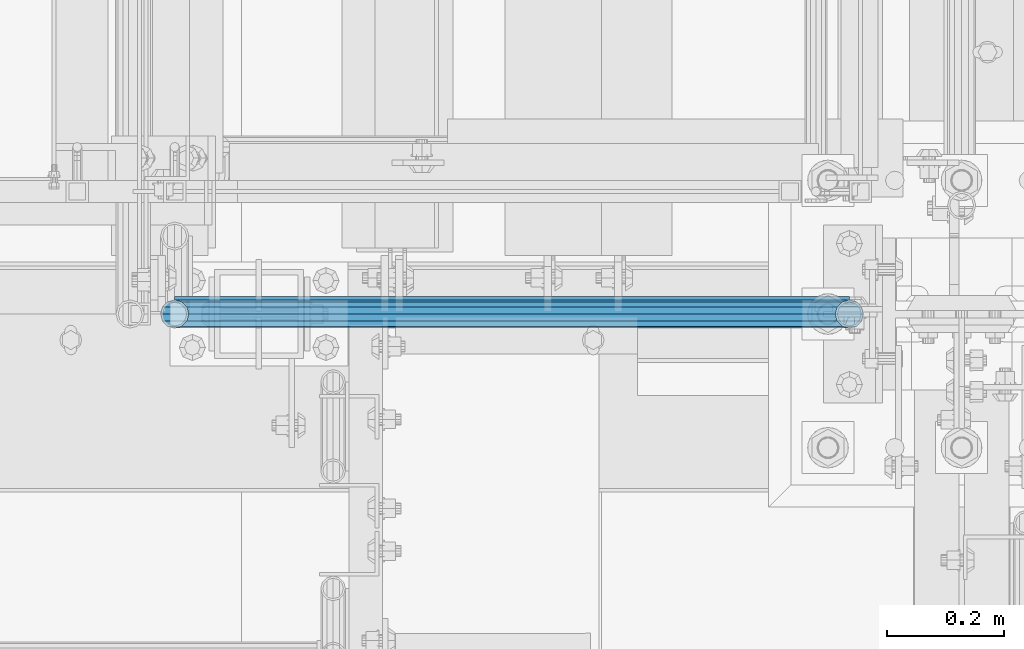
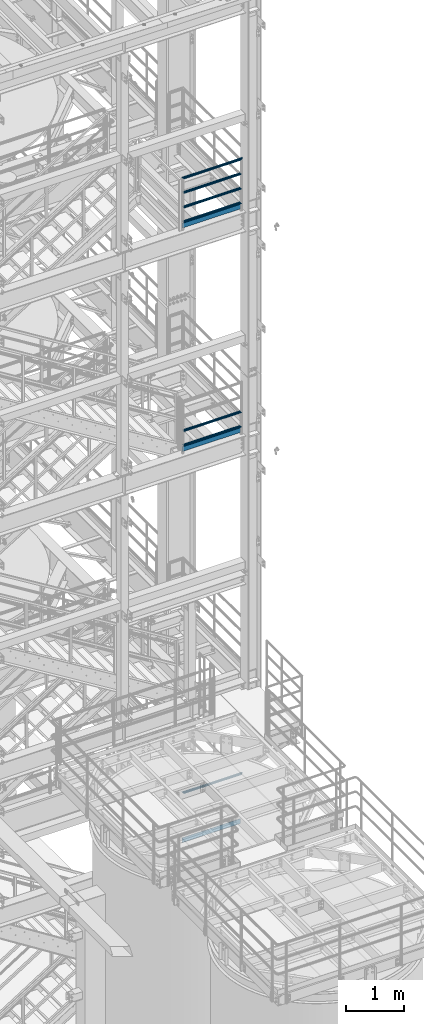
# One storey, part 949 of 1876: 10 beams, 3 elements without a shape of their own.
"""IFC2X3 building model written with IfcOpenShell, lengths in millimetres."""

from ifc_helpers import new_model, si_unit, frame, origin_with_axes, place, context, subcontext, project, spatial, faceted_brep, material, type_object, element, aggregate, save


model = new_model("IFC2X3")

# Units and contexts
model_context = context("Model", 3, precision=1e-05, world=origin_with_axes())
body_context = subcontext(model_context, "Body", "Model", "MODEL_VIEW")
ifc_project = project(units=[si_unit("LENGTHUNIT", "METRE", prefix="MILLI"), si_unit("AREAUNIT", "SQUARE_METRE"), si_unit("VOLUMEUNIT", "CUBIC_METRE"), si_unit("MASSUNIT", "GRAM", prefix="KILO"), si_unit("TIMEUNIT", "SECOND"), si_unit("PLANEANGLEUNIT", "RADIAN"), si_unit("SOLIDANGLEUNIT", "STERADIAN"), si_unit("THERMODYNAMICTEMPERATUREUNIT", "DEGREE_CELSIUS"), si_unit("LUMINOUSINTENSITYUNIT", "LUMEN")], contexts=[model_context])

# Site, building, storey
site_placement = place(None, origin_with_axes())
site = spatial("IfcSite", under=ifc_project, at=site_placement, CompositionType="ELEMENT")
building_placement = place(site_placement, origin_with_axes())
building = spatial("IfcBuilding", under=site, at=building_placement, Name="Undefined", CompositionType="ELEMENT")
storey_placement = place(building_placement, origin_with_axes())
storey = spatial("IfcBuildingStorey", under=building, at=storey_placement, Name="Undefined", CompositionType="ELEMENT", Elevation=0.0)

# Assembly, beam
assembly_1_placement = place(storey_placement, origin_with_axes())
assembly_1 = element("IfcElementAssembly", 1, at=assembly_1_placement, inside=storey, Name="RAIL", AssemblyPlace="NOTDEFINED", PredefinedType="RIGID_FRAME")
ifc_material_1 = material()
beam_type_1 = type_object("IfcBeamType", Name="PIPE1-1/2SCH40", PredefinedType="NOTDEFINED")
beam_1_placement = place(assembly_1_placement, frame((6249.67016410903, -7112.0, 6207.12499999999), z_axis=(0.0, 0.0, -1.0), x_axis=(1.0, 0.0, 0.0)))
beam_1 = element("IfcBeam", 2, at=beam_1_placement, type_object=beam_type_1, material=ifc_material_1, Name="RAIL", ObjectType="PIPE1-1/2SCH40", context=body_context, shape_type="Brep", body=[
    faceted_brep([(24.1300000000001, -20.4469999999999, 0.0), (34.3535000000002, -17.7076214311803, 10.2235000000001), (1168.01883589097, -17.7076214311801, 10.2235000000001), (1178.24233589097, -20.4470000000001, 0.0), (41.8376214311802, -10.2235000000001, 17.7076214311819), (1160.53471445979, -10.2235000000001, 17.7076214311801), (44.5770000000002, 0.0, 20.4470000000001), (1157.79533589097, 0.0, 20.4470000000001), (41.8376214311802, 10.2235000000001, 17.7076214311819), (1160.53471445979, 10.2235000000001, 17.7076214311801), (34.3535000000002, 17.7076214311803, 10.2235000000001), (1168.01883589097, 17.7076214311801, 10.2235000000001), (24.1300000000001, 20.4469999999999, 0.0), (1178.24233589097, 20.4470000000001, 0.0), (13.9065000000001, 17.7076214311803, -10.2235000000001), (1188.46583589097, 17.7076214311801, -10.2235000000001), (6.42237856882002, 10.2235000000001, -17.7076214311819), (1195.94995732215, 10.2235000000001, -17.7076214311801), (3.68299999999999, 0.0, -20.4470000000001), (1198.68933589097, 0.0, -20.4470000000001), (6.42237856882002, -10.2235000000001, -17.7076214311819), (1195.94995732215, -10.2235000000001, -17.7076214311801), (13.9065000000001, -17.7076214311803, -10.2235000000001), (1188.46583589097, -17.7076214311801, -10.2235000000001), (24.1299999999854, -24.1299999999992, 0.0), (12.0650000000064, -20.8971929933177, -12.0649999999987), (1190.30733589097, -20.8971929933186, -12.0649999999996), (1178.24233589097, -24.1300000000001, 0.0), (3.23280700668147, -12.0650000000001, -20.8971929933177), (1199.13952888429, -12.0649999999996, -20.8971929933186), (-1.45519152283669e-11, 0.0, -24.130000000001), (1202.37233589097, 0.0, -24.1300000000001), (3.23280700668147, 12.0650000000001, -20.8971929933177), (1199.13952888429, 12.0649999999996, -20.8971929933186), (12.0650000000064, 20.8971929933177, -12.0649999999987), (1190.30733589097, 20.8971929933186, -12.0649999999996), (24.1300000000047, 24.1299999999992, 0.0), (1178.24233589097, 24.1300000000001, 0.0), (36.1949999999997, 20.8971929933184, 12.0649999999987), (1166.17733589097, 20.8971929933186, 12.0649999999996), (45.0271929933187, 12.0650000000001, 20.8971929933177), (1157.34514289765, 12.0649999999996, 20.8971929933186), (48.2600000000002, 0.0, 24.130000000001), (1154.11233589097, 0.0, 24.1300000000001), (45.0271929933187, -12.0650000000001, 20.8971929933177), (1157.34514289765, -12.0649999999996, 20.8971929933186), (36.1949999999997, -20.8971929933184, 12.0649999999987), (1166.17733589097, -20.8971929933186, 12.0649999999996)], [[[0, 1, 2, 3]], [[1, 4, 5, 2]], [[4, 6, 7, 5]], [[6, 8, 9, 7]], [[8, 10, 11, 9]], [[10, 12, 13, 11]], [[12, 14, 15, 13]], [[14, 16, 17, 15]], [[16, 18, 19, 17]], [[18, 20, 21, 19]], [[20, 22, 23, 21]], [[22, 0, 3, 23]], [[24, 25, 26, 27]], [[25, 28, 29, 26]], [[28, 30, 31, 29]], [[30, 32, 33, 31]], [[32, 34, 35, 33]], [[34, 36, 37, 35]], [[36, 38, 39, 37]], [[38, 40, 41, 39]], [[40, 42, 43, 41]], [[42, 44, 45, 43]], [[44, 46, 47, 45]], [[46, 24, 27, 47]], [[29, 31, 33, 35, 37, 39, 41, 43, 45, 47, 27, 26], [5, 7, 9, 11, 13, 15, 17, 19, 21, 23, 3, 2]], [[46, 44, 42, 40, 38, 36, 34, 32, 30, 28, 25, 24], [22, 20, 18, 16, 14, 12, 10, 8, 6, 4, 1, 0]]]),
])

# Assembly, beams
assembly_2_placement = place(storey_placement, origin_with_axes())
assembly_2 = element("IfcElementAssembly", 3, at=assembly_2_placement, inside=storey, Name="RAIL", AssemblyPlace="NOTDEFINED", PredefinedType="RIGID_FRAME")
beam_2_placement = place(assembly_2_placement, frame((7427.9125, -7112.0, 18145.125), z_axis=(0.0, 0.0, 1.0), x_axis=(-1.0, 0.0, 0.0)))
beam_2 = element("IfcBeam", 4, at=beam_2_placement, type_object=beam_type_1, material=ifc_material_1, Name="RAIL", ObjectType="PIPE1-1/2SCH40", context=body_context, shape_type="Brep", body=[
    faceted_brep([(1133.21514289765, -12.0649999999996, 20.8971929933186), (1133.21514289765, -12.0649999999996, 15.8661214311805), (1132.72171445979, -10.2235000000001, 17.7076214311801), (1129.98233589097, 0.0, 20.4470000000001), (1129.98233589097, 0.0, 24.1300000000001), (1132.72171445979, 10.2235000000001, 17.7076214311801), (1133.21514289765, 12.0649999999996, 15.8661214311805), (1133.21514289765, 12.0649999999996, 20.8971929933186), (1154.11233589097, 24.1300000000001, 0.0), (1142.04733589097, 20.8971929933186, 12.0649999999996), (1142.04733589097, 20.8971929933186, -12.0649999999996), (1138.85776432883, 17.7076214311801, 10.2235000000001), (1141.59714289765, 20.4470000000001, 0.0), (1138.85776432883, 17.7076214311801, -10.2235000000001), (1133.21514289765, 12.0649999999996, -15.8661214311805), (1133.21514289765, 12.0649999999996, -20.8971929933186), (1132.72171445979, 10.2235000000001, -17.7076214311801), (1129.98233589097, 0.0, -20.4470000000001), (1129.98233589097, 0.0, -24.1300000000001), (1133.21514289765, -12.0649999999996, -15.8661214311805), (1133.21514289765, -12.0649999999996, -20.8971929933186), (1132.72171445979, -10.2235000000001, -17.7076214311801), (1154.11233589097, -24.1300000000001, 0.0), (1142.04733589097, -20.8971929933186, -12.0649999999996), (1142.04733589097, -20.8971929933186, 12.0649999999996), (1138.85776432883, -17.7076214311801, -10.2235000000001), (1141.59714289765, -20.4470000000001, 0.0), (1138.85776432883, -17.7076214311801, 10.2235000000001), (12.0650000000064, -20.8971929933177, -12.0649999999987), (20.8971929933249, -12.0650000000005, -20.8971929933177), (0.0, 24.1299999999992, 0.0), (12.0650000000064, 20.8971929933177, -12.0649999999987), (12.0650000000064, 20.8971929933177, 12.0649999999987), (20.8971929933249, 12.0650000000005, 20.8971929933177), (24.1300000000064, 0.0, 24.130000000001), (20.8971929933249, 12.0650000000005, -20.8971929933177), (24.1300000000063, 0.0, -24.130000000001), (24.1300000000063, 0.0, -20.4470000000001), (20.8971929933249, -12.0650000000005, -15.8661214311796), (21.3906214311868, -10.2235000000001, -17.7076214311819), (21.3906214311868, 10.2235000000001, -17.7076214311819), (20.8971929933249, 12.0650000000005, -15.8661214311796), (15.2545715621445, 17.7076214311801, -10.2235000000001), (12.5151929933249, 20.4470000000001, 0.0), (15.2545715621445, 17.7076214311801, 10.2235000000001), (20.8971929933249, 12.0650000000005, 15.8661214311796), (21.3906214311868, 10.2235000000001, 17.7076214311819), (24.1300000000064, 0.0, 20.4470000000001), (21.3906214311868, -10.2235000000001, 17.7076214311819), (20.8971929933249, -12.0650000000005, 15.8661214311796), (20.8971929933249, -12.0650000000005, 20.8971929933177), (12.0650000000064, -20.8971929933177, 12.0649999999987), (0.0, -24.1299999999992, 0.0), (15.2545715621445, -17.7076214311801, 10.2235000000001), (12.5151929933249, -20.4470000000001, 0.0), (15.2545715621445, -17.7076214311801, -10.2235000000001)], [[[0, 1, 2, 3, 4]], [[4, 3, 5, 6, 7]], [[8, 9, 10]], [[7, 6, 11, 12, 13, 14, 15, 10, 9]], [[16, 17, 18, 15, 14]], [[19, 20, 18, 17, 21]], [[22, 23, 24]], [[24, 23, 20, 19, 25, 26, 27, 1, 0]], [[28, 29, 20, 23]], [[30, 31, 32]], [[33, 34, 4, 7]], [[32, 33, 7, 9]], [[30, 32, 9, 8]], [[31, 30, 8, 10]], [[35, 31, 10, 15]], [[36, 35, 15, 18]], [[29, 36, 18, 20]], [[37, 36, 29, 38, 39]], [[40, 41, 35, 36, 37]], [[32, 31, 35, 41, 42, 43, 44, 45, 33]], [[33, 45, 46, 47, 34]], [[34, 47, 48, 49, 50]], [[34, 50, 0, 4]], [[50, 51, 24, 0]], [[51, 52, 22, 24]], [[52, 28, 23, 22]], [[51, 28, 52]], [[50, 49, 53, 54, 55, 38, 29, 28, 51]], [[55, 54, 26, 25]], [[21, 39, 38, 55, 25, 19]], [[37, 39, 21, 17]], [[40, 37, 17, 16]], [[42, 41, 40, 16, 14, 13]], [[43, 42, 13, 12]], [[44, 43, 12, 11]], [[5, 46, 45, 44, 11, 6]], [[47, 46, 5, 3]], [[48, 47, 3, 2]], [[53, 49, 48, 2, 1, 27]], [[54, 53, 27, 26]]]),
])
beam_3_placement = place(assembly_2_placement, frame((6273.80016410903, -7112.0, 18449.925), z_axis=(0.0, 0.0, -1.0), x_axis=(1.0, 0.0, 0.0)))
beam_3 = element("IfcBeam", 5, at=beam_3_placement, type_object=beam_type_1, material=ifc_material_1, Name="RAIL", ObjectType="PIPE1-1/2SCH40", context=body_context, shape_type="Brep", body=[
    faceted_brep([(0.0, 24.1299999999992, 0.0), (12.0650000000064, 20.8971929933177, -12.0649999999987), (12.0650000000064, 20.8971929933177, 12.0649999999987), (12.0650000000064, -20.8971929933177, 12.0649999999987), (12.0650000000064, -20.8971929933177, -12.0649999999987), (0.0, -24.1299999999992, 0.0), (20.8971929933249, -12.0650000000005, 20.8971929933177), (20.8971929933249, -12.0650000000005, 15.8661214311796), (15.2545715621445, -17.7076214311801, 10.2235000000001), (12.5151929933249, -20.4470000000001, 0.0), (15.2545715621445, -17.7076214311801, -10.2235000000001), (20.8971929933249, -12.0650000000005, -15.8661214311796), (20.8971929933249, -12.0650000000005, -20.8971929933177), (24.1300000000063, 0.0, -20.4470000000001), (24.1300000000063, 0.0, -24.130000000001), (21.3906214311868, -10.2235000000001, -17.7076214311819), (21.3906214311868, 10.2235000000001, -17.7076214311819), (20.8971929933249, 12.0650000000005, -15.8661214311796), (20.8971929933249, 12.0650000000005, -20.8971929933177), (15.2545715621445, 17.7076214311801, -10.2235000000001), (12.5151929933249, 20.4470000000001, 0.0), (15.2545715621445, 17.7076214311801, 10.2235000000001), (20.8971929933249, 12.0650000000005, 15.8661214311796), (20.8971929933249, 12.0650000000005, 20.8971929933177), (21.3906214311868, 10.2235000000001, 17.7076214311819), (24.1300000000064, 0.0, 20.4470000000001), (24.1300000000064, 0.0, 24.130000000001), (21.3906214311868, -10.2235000000001, 17.7076214311819), (1154.11233589097, 24.1300000000001, 0.0), (1142.04733589097, 20.8971929933186, -12.0649999999996), (1133.21514289765, 12.0649999999996, -20.8971929933186), (1154.11233589097, -24.1300000000001, 0.0), (1142.04733589097, -20.8971929933186, -12.0649999999996), (1142.04733589097, -20.8971929933186, 12.0649999999996), (1133.21514289765, -12.0649999999996, 20.8971929933186), (1133.21514289765, -12.0649999999996, -20.8971929933186), (1129.98233589097, 0.0, -24.1300000000001), (1132.72171445979, 10.2235000000001, -17.7076214311801), (1129.98233589097, 0.0, -20.4470000000001), (1133.21514289765, 12.0649999999996, -15.8661214311805), (1133.21514289765, -12.0649999999996, -15.8661214311805), (1132.72171445979, -10.2235000000001, -17.7076214311801), (1138.85776432883, -17.7076214311801, -10.2235000000001), (1141.59714289765, -20.4470000000001, 0.0), (1138.85776432883, -17.7076214311801, 10.2235000000001), (1133.21514289765, -12.0649999999996, 15.8661214311805), (1132.72171445979, -10.2235000000001, 17.7076214311801), (1129.98233589097, 0.0, 20.4470000000001), (1129.98233589097, 0.0, 24.1300000000001), (1133.21514289765, 12.0649999999996, 20.8971929933186), (1142.04733589097, 20.8971929933186, 12.0649999999996), (1133.21514289765, 12.0649999999996, 15.8661214311805), (1138.85776432883, 17.7076214311801, 10.2235000000001), (1141.59714289765, 20.4470000000001, 0.0), (1138.85776432883, 17.7076214311801, -10.2235000000001), (1132.72171445979, 10.2235000000001, 17.7076214311801)], [[[0, 1, 2]], [[3, 4, 5]], [[6, 7, 8, 9, 10, 11, 12, 4, 3]], [[13, 14, 12, 11, 15]], [[16, 17, 18, 14, 13]], [[2, 1, 18, 17, 19, 20, 21, 22, 23]], [[23, 22, 24, 25, 26]], [[26, 25, 27, 7, 6]], [[1, 0, 28, 29]], [[18, 1, 29, 30]], [[31, 32, 33]], [[6, 3, 33, 34]], [[3, 5, 31, 33]], [[5, 4, 32, 31]], [[4, 12, 35, 32]], [[12, 14, 36, 35]], [[14, 18, 30, 36]], [[37, 38, 36, 30, 39]], [[40, 35, 36, 38, 41]], [[33, 32, 35, 40, 42, 43, 44, 45, 34]], [[34, 45, 46, 47, 48]], [[26, 6, 34, 48]], [[2, 23, 49, 50]], [[23, 26, 48, 49]], [[0, 2, 50, 28]], [[28, 50, 29]], [[49, 51, 52, 53, 54, 39, 30, 29, 50]], [[48, 47, 55, 51, 49]], [[25, 24, 55, 47]], [[55, 24, 22, 21, 52, 51]], [[21, 20, 53, 52]], [[20, 19, 54, 53]], [[19, 17, 16, 37, 39, 54]], [[16, 13, 38, 37]], [[13, 15, 41, 38]], [[41, 15, 11, 10, 42, 40]], [[10, 9, 43, 42]], [[9, 8, 44, 43]], [[8, 7, 27, 46, 45, 44]], [[27, 25, 47, 46]]]),
])
beam_4_placement = place(assembly_2_placement, frame((6273.80016410903, -7112.0, 18754.725), z_axis=(0.0, 0.0, -1.0), x_axis=(1.0, 0.0, 0.0)))
beam_4 = element("IfcBeam", 6, at=beam_4_placement, type_object=beam_type_1, material=ifc_material_1, Name="RAIL", ObjectType="PIPE1-1/2SCH40", context=body_context, shape_type="Brep", body=[
    faceted_brep([(0.0, 24.1299999999992, 0.0), (12.0650000000064, 20.8971929933177, -12.0649999999987), (12.0650000000064, 20.8971929933177, 12.0649999999987), (12.0650000000064, -20.8971929933177, 12.0649999999987), (12.0650000000064, -20.8971929933177, -12.0649999999987), (0.0, -24.1299999999992, 0.0), (20.8971929933249, -12.0650000000005, 20.8971929933177), (20.8971929933249, -12.0650000000005, 15.8661214311796), (15.2545715621445, -17.7076214311801, 10.2235000000001), (12.5151929933249, -20.4470000000001, 0.0), (15.2545715621445, -17.7076214311801, -10.2235000000001), (20.8971929933249, -12.0650000000005, -15.8661214311796), (20.8971929933249, -12.0650000000005, -20.8971929933177), (24.1300000000063, 0.0, -20.4470000000001), (24.1300000000063, 0.0, -24.130000000001), (21.3906214311868, -10.2235000000001, -17.7076214311819), (21.3906214311868, 10.2235000000001, -17.7076214311819), (20.8971929933249, 12.0650000000005, -15.8661214311796), (20.8971929933249, 12.0650000000005, -20.8971929933177), (15.2545715621445, 17.7076214311801, -10.2235000000001), (12.5151929933249, 20.4470000000001, 0.0), (15.2545715621445, 17.7076214311801, 10.2235000000001), (20.8971929933249, 12.0650000000005, 15.8661214311796), (20.8971929933249, 12.0650000000005, 20.8971929933177), (21.3906214311868, 10.2235000000001, 17.7076214311819), (24.1300000000064, 0.0, 20.4470000000001), (24.1300000000064, 0.0, 24.130000000001), (21.3906214311868, -10.2235000000001, 17.7076214311819), (1154.11233589097, 24.1300000000001, 0.0), (1142.04733589097, 20.8971929933186, -12.0649999999996), (1133.21514289765, 12.0649999999996, -20.8971929933186), (1154.11233589097, -24.1300000000001, 0.0), (1142.04733589097, -20.8971929933186, -12.0649999999996), (1142.04733589097, -20.8971929933186, 12.0649999999996), (1133.21514289765, -12.0649999999996, 20.8971929933186), (1133.21514289765, -12.0649999999996, -20.8971929933186), (1129.98233589097, 0.0, -24.1300000000001), (1132.72171445979, 10.2235000000001, -17.7076214311801), (1129.98233589097, 0.0, -20.4470000000001), (1133.21514289765, 12.0649999999996, -15.8661214311805), (1133.21514289765, -12.0649999999996, -15.8661214311805), (1132.72171445979, -10.2235000000001, -17.7076214311801), (1138.85776432883, -17.7076214311801, -10.2235000000001), (1141.59714289765, -20.4470000000001, 0.0), (1138.85776432883, -17.7076214311801, 10.2235000000001), (1133.21514289765, -12.0649999999996, 15.8661214311805), (1132.72171445979, -10.2235000000001, 17.7076214311801), (1129.98233589097, 0.0, 20.4470000000001), (1129.98233589097, 0.0, 24.1300000000001), (1133.21514289765, 12.0649999999996, 20.8971929933186), (1142.04733589097, 20.8971929933186, 12.0649999999996), (1133.21514289765, 12.0649999999996, 15.8661214311805), (1138.85776432883, 17.7076214311801, 10.2235000000001), (1141.59714289765, 20.4470000000001, 0.0), (1138.85776432883, 17.7076214311801, -10.2235000000001), (1132.72171445979, 10.2235000000001, 17.7076214311801)], [[[0, 1, 2]], [[3, 4, 5]], [[6, 7, 8, 9, 10, 11, 12, 4, 3]], [[13, 14, 12, 11, 15]], [[16, 17, 18, 14, 13]], [[2, 1, 18, 17, 19, 20, 21, 22, 23]], [[23, 22, 24, 25, 26]], [[26, 25, 27, 7, 6]], [[1, 0, 28, 29]], [[18, 1, 29, 30]], [[31, 32, 33]], [[6, 3, 33, 34]], [[3, 5, 31, 33]], [[5, 4, 32, 31]], [[4, 12, 35, 32]], [[12, 14, 36, 35]], [[14, 18, 30, 36]], [[37, 38, 36, 30, 39]], [[40, 35, 36, 38, 41]], [[33, 32, 35, 40, 42, 43, 44, 45, 34]], [[34, 45, 46, 47, 48]], [[26, 6, 34, 48]], [[2, 23, 49, 50]], [[23, 26, 48, 49]], [[0, 2, 50, 28]], [[28, 50, 29]], [[49, 51, 52, 53, 54, 39, 30, 29, 50]], [[48, 47, 55, 51, 49]], [[25, 24, 55, 47]], [[55, 24, 22, 21, 52, 51]], [[21, 20, 53, 52]], [[20, 19, 54, 53]], [[19, 17, 16, 37, 39, 54]], [[16, 13, 38, 37]], [[13, 15, 41, 38]], [[41, 15, 11, 10, 42, 40]], [[10, 9, 43, 42]], [[9, 8, 44, 43]], [[8, 7, 27, 46, 45, 44]], [[27, 25, 47, 46]]]),
])
beam_5_placement = place(assembly_2_placement, frame((6249.67016410903, -7112.0, 19059.525), z_axis=(0.0, 0.0, -1.0), x_axis=(1.0, 0.0, 0.0)))
beam_5 = element("IfcBeam", 7, at=beam_5_placement, type_object=beam_type_1, material=ifc_material_1, Name="RAIL", ObjectType="PIPE1-1/2SCH40", context=body_context, shape_type="Brep", body=[
    faceted_brep([(24.1300000000001, -20.4469999999999, 0.0), (34.3535000000002, -17.7076214311803, 10.2235000000001), (1168.01883589097, -17.7076214311801, 10.2235000000001), (1178.24233589097, -20.4470000000001, 0.0), (41.8376214311802, -10.2235000000001, 17.7076214311819), (1160.53471445979, -10.2235000000001, 17.7076214311801), (44.5770000000002, 0.0, 20.4470000000001), (1157.79533589097, 0.0, 20.4470000000001), (41.8376214311802, 10.2235000000001, 17.7076214311819), (1160.53471445979, 10.2235000000001, 17.7076214311801), (34.3535000000002, 17.7076214311803, 10.2235000000001), (1168.01883589097, 17.7076214311801, 10.2235000000001), (24.1300000000001, 20.4469999999999, 0.0), (1178.24233589097, 20.4470000000001, 0.0), (13.9065000000001, 17.7076214311803, -10.2235000000001), (1188.46583589097, 17.7076214311801, -10.2235000000001), (6.42237856882002, 10.2235000000001, -17.7076214311819), (1195.94995732215, 10.2235000000001, -17.7076214311801), (3.68299999999999, 0.0, -20.4470000000001), (1198.68933589097, 0.0, -20.4470000000001), (6.42237856882002, -10.2235000000001, -17.7076214311819), (1195.94995732215, -10.2235000000001, -17.7076214311801), (13.9065000000001, -17.7076214311803, -10.2235000000001), (1188.46583589097, -17.7076214311801, -10.2235000000001), (24.1299999999854, -24.1299999999992, 0.0), (12.0650000000064, -20.8971929933177, -12.0649999999987), (1190.30733589097, -20.8971929933186, -12.0649999999996), (1178.24233589097, -24.1300000000001, 0.0), (3.23280700668147, -12.0650000000001, -20.8971929933177), (1199.13952888429, -12.0649999999996, -20.8971929933186), (-1.45519152283669e-11, 0.0, -24.130000000001), (1202.37233589097, 0.0, -24.1300000000001), (3.23280700668147, 12.0650000000001, -20.8971929933177), (1199.13952888429, 12.0649999999996, -20.8971929933186), (12.0650000000064, 20.8971929933177, -12.0649999999987), (1190.30733589097, 20.8971929933186, -12.0649999999996), (24.1300000000047, 24.1299999999992, 0.0), (1178.24233589097, 24.1300000000001, 0.0), (36.1949999999997, 20.8971929933184, 12.0649999999987), (1166.17733589097, 20.8971929933186, 12.0649999999996), (45.0271929933187, 12.0650000000001, 20.8971929933177), (1157.34514289765, 12.0649999999996, 20.8971929933186), (48.2600000000002, 0.0, 24.130000000001), (1154.11233589097, 0.0, 24.1300000000001), (45.0271929933187, -12.0650000000001, 20.8971929933177), (1157.34514289765, -12.0649999999996, 20.8971929933186), (36.1949999999997, -20.8971929933184, 12.0649999999987), (1166.17733589097, -20.8971929933186, 12.0649999999996)], [[[0, 1, 2, 3]], [[1, 4, 5, 2]], [[4, 6, 7, 5]], [[6, 8, 9, 7]], [[8, 10, 11, 9]], [[10, 12, 13, 11]], [[12, 14, 15, 13]], [[14, 16, 17, 15]], [[16, 18, 19, 17]], [[18, 20, 21, 19]], [[20, 22, 23, 21]], [[22, 0, 3, 23]], [[24, 25, 26, 27]], [[25, 28, 29, 26]], [[28, 30, 31, 29]], [[30, 32, 33, 31]], [[32, 34, 35, 33]], [[34, 36, 37, 35]], [[36, 38, 39, 37]], [[38, 40, 41, 39]], [[40, 42, 43, 41]], [[42, 44, 45, 43]], [[44, 46, 47, 45]], [[46, 24, 27, 47]], [[29, 31, 33, 35, 37, 39, 41, 43, 45, 47, 27, 26], [5, 7, 9, 11, 13, 15, 17, 19, 21, 23, 3, 2]], [[46, 44, 42, 40, 38, 36, 34, 32, 30, 28, 25, 24], [22, 20, 18, 16, 14, 12, 10, 8, 6, 4, 1, 0]]]),
])

assembly_3_placement = place(storey_placement, origin_with_axes())
assembly_3 = element("IfcElementAssembly", 8, at=assembly_3_placement, inside=storey, Name="RAIL", AssemblyPlace="NOTDEFINED", PredefinedType="RIGID_FRAME")
beam_6_placement = place(assembly_3_placement, frame((7427.9125, -7112.0, 13471.525), z_axis=(0.0, 0.0, 1.0), x_axis=(-1.0, 0.0, 0.0)))
beam_6 = element("IfcBeam", 9, at=beam_6_placement, type_object=beam_type_1, material=ifc_material_1, Name="RAIL", ObjectType="PIPE1-1/2SCH40", context=body_context, shape_type="Brep", body=[
    faceted_brep([(1133.21514289765, -12.0649999999996, 20.8971929933186), (1133.21514289765, -12.0649999999996, 15.8661214311805), (1132.72171445979, -10.2235000000001, 17.7076214311801), (1129.98233589097, 0.0, 20.4470000000001), (1129.98233589097, 0.0, 24.1300000000001), (1132.72171445979, 10.2235000000001, 17.7076214311801), (1133.21514289765, 12.0649999999996, 15.8661214311805), (1133.21514289765, 12.0649999999996, 20.8971929933186), (1154.11233589097, 24.1300000000001, 0.0), (1142.04733589097, 20.8971929933186, 12.0649999999996), (1142.04733589097, 20.8971929933186, -12.0649999999996), (1138.85776432883, 17.7076214311801, 10.2235000000001), (1141.59714289765, 20.4470000000001, 0.0), (1138.85776432883, 17.7076214311801, -10.2235000000001), (1133.21514289765, 12.0649999999996, -15.8661214311805), (1133.21514289765, 12.0649999999996, -20.8971929933186), (1132.72171445979, 10.2235000000001, -17.7076214311801), (1129.98233589097, 0.0, -20.4470000000001), (1129.98233589097, 0.0, -24.1300000000001), (1133.21514289765, -12.0649999999996, -15.8661214311805), (1133.21514289765, -12.0649999999996, -20.8971929933186), (1132.72171445979, -10.2235000000001, -17.7076214311801), (1154.11233589097, -24.1300000000001, 0.0), (1142.04733589097, -20.8971929933186, -12.0649999999996), (1142.04733589097, -20.8971929933186, 12.0649999999996), (1138.85776432883, -17.7076214311801, -10.2235000000001), (1141.59714289765, -20.4470000000001, 0.0), (1138.85776432883, -17.7076214311801, 10.2235000000001), (12.0650000000064, -20.8971929933177, -12.0649999999987), (20.8971929933249, -12.0650000000005, -20.8971929933177), (0.0, 24.1299999999992, 0.0), (12.0650000000064, 20.8971929933177, -12.0649999999987), (12.0650000000064, 20.8971929933177, 12.0649999999987), (20.8971929933249, 12.0650000000005, 20.8971929933177), (24.1300000000064, 0.0, 24.130000000001), (20.8971929933249, 12.0650000000005, -20.8971929933177), (24.1300000000063, 0.0, -24.130000000001), (24.1300000000063, 0.0, -20.4470000000001), (20.8971929933249, -12.0650000000005, -15.8661214311796), (21.3906214311868, -10.2235000000001, -17.7076214311819), (21.3906214311868, 10.2235000000001, -17.7076214311819), (20.8971929933249, 12.0650000000005, -15.8661214311796), (15.2545715621445, 17.7076214311801, -10.2235000000001), (12.5151929933249, 20.4470000000001, 0.0), (15.2545715621445, 17.7076214311801, 10.2235000000001), (20.8971929933249, 12.0650000000005, 15.8661214311796), (21.3906214311868, 10.2235000000001, 17.7076214311819), (24.1300000000064, 0.0, 20.4470000000001), (21.3906214311868, -10.2235000000001, 17.7076214311819), (20.8971929933249, -12.0650000000005, 15.8661214311796), (20.8971929933249, -12.0650000000005, 20.8971929933177), (12.0650000000064, -20.8971929933177, 12.0649999999987), (0.0, -24.1299999999992, 0.0), (15.2545715621445, -17.7076214311801, 10.2235000000001), (12.5151929933249, -20.4470000000001, 0.0), (15.2545715621445, -17.7076214311801, -10.2235000000001)], [[[0, 1, 2, 3, 4]], [[4, 3, 5, 6, 7]], [[8, 9, 10]], [[7, 6, 11, 12, 13, 14, 15, 10, 9]], [[16, 17, 18, 15, 14]], [[19, 20, 18, 17, 21]], [[22, 23, 24]], [[24, 23, 20, 19, 25, 26, 27, 1, 0]], [[28, 29, 20, 23]], [[30, 31, 32]], [[33, 34, 4, 7]], [[32, 33, 7, 9]], [[30, 32, 9, 8]], [[31, 30, 8, 10]], [[35, 31, 10, 15]], [[36, 35, 15, 18]], [[29, 36, 18, 20]], [[37, 36, 29, 38, 39]], [[40, 41, 35, 36, 37]], [[32, 31, 35, 41, 42, 43, 44, 45, 33]], [[33, 45, 46, 47, 34]], [[34, 47, 48, 49, 50]], [[34, 50, 0, 4]], [[50, 51, 24, 0]], [[51, 52, 22, 24]], [[52, 28, 23, 22]], [[51, 28, 52]], [[50, 49, 53, 54, 55, 38, 29, 28, 51]], [[55, 54, 26, 25]], [[21, 39, 38, 55, 25, 19]], [[37, 39, 21, 17]], [[40, 37, 17, 16]], [[42, 41, 40, 16, 14, 13]], [[43, 42, 13, 12]], [[44, 43, 12, 11]], [[5, 46, 45, 44, 11, 6]], [[47, 46, 5, 3]], [[48, 47, 3, 2]], [[53, 49, 48, 2, 1, 27]], [[54, 53, 27, 26]]]),
])
beam_7_placement = place(assembly_3_placement, frame((6273.80016410903, -7112.0, 13776.325), z_axis=(0.0, 0.0, -1.0), x_axis=(1.0, 0.0, 0.0)))
beam_7 = element("IfcBeam", 10, at=beam_7_placement, type_object=beam_type_1, material=ifc_material_1, Name="RAIL", ObjectType="PIPE1-1/2SCH40", context=body_context, shape_type="Brep", body=[
    faceted_brep([(0.0, 24.1299999999992, 0.0), (12.0650000000064, 20.8971929933177, -12.0649999999987), (12.0650000000064, 20.8971929933177, 12.0649999999987), (12.0650000000064, -20.8971929933177, 12.0649999999987), (12.0650000000064, -20.8971929933177, -12.0649999999987), (0.0, -24.1299999999992, 0.0), (20.8971929933249, -12.0650000000005, 20.8971929933177), (20.8971929933249, -12.0650000000005, 15.8661214311796), (15.2545715621445, -17.7076214311801, 10.2235000000001), (12.5151929933249, -20.4470000000001, 0.0), (15.2545715621445, -17.7076214311801, -10.2235000000001), (20.8971929933249, -12.0650000000005, -15.8661214311796), (20.8971929933249, -12.0650000000005, -20.8971929933177), (24.1300000000063, 0.0, -20.4470000000001), (24.1300000000063, 0.0, -24.130000000001), (21.3906214311868, -10.2235000000001, -17.7076214311819), (21.3906214311868, 10.2235000000001, -17.7076214311819), (20.8971929933249, 12.0650000000005, -15.8661214311796), (20.8971929933249, 12.0650000000005, -20.8971929933177), (15.2545715621445, 17.7076214311801, -10.2235000000001), (12.5151929933249, 20.4470000000001, 0.0), (15.2545715621445, 17.7076214311801, 10.2235000000001), (20.8971929933249, 12.0650000000005, 15.8661214311796), (20.8971929933249, 12.0650000000005, 20.8971929933177), (21.3906214311868, 10.2235000000001, 17.7076214311819), (24.1300000000064, 0.0, 20.4470000000001), (24.1300000000064, 0.0, 24.130000000001), (21.3906214311868, -10.2235000000001, 17.7076214311819), (1154.11233589097, 24.1300000000001, 0.0), (1142.04733589097, 20.8971929933186, -12.0649999999996), (1133.21514289765, 12.0649999999996, -20.8971929933186), (1154.11233589097, -24.1300000000001, 0.0), (1142.04733589097, -20.8971929933186, -12.0649999999996), (1142.04733589097, -20.8971929933186, 12.0649999999996), (1133.21514289765, -12.0649999999996, 20.8971929933186), (1133.21514289765, -12.0649999999996, -20.8971929933186), (1129.98233589097, 0.0, -24.1300000000001), (1132.72171445979, 10.2235000000001, -17.7076214311801), (1129.98233589097, 0.0, -20.4470000000001), (1133.21514289765, 12.0649999999996, -15.8661214311805), (1133.21514289765, -12.0649999999996, -15.8661214311805), (1132.72171445979, -10.2235000000001, -17.7076214311801), (1138.85776432883, -17.7076214311801, -10.2235000000001), (1141.59714289765, -20.4470000000001, 0.0), (1138.85776432883, -17.7076214311801, 10.2235000000001), (1133.21514289765, -12.0649999999996, 15.8661214311805), (1132.72171445979, -10.2235000000001, 17.7076214311801), (1129.98233589097, 0.0, 20.4470000000001), (1129.98233589097, 0.0, 24.1300000000001), (1133.21514289765, 12.0649999999996, 20.8971929933186), (1142.04733589097, 20.8971929933186, 12.0649999999996), (1133.21514289765, 12.0649999999996, 15.8661214311805), (1138.85776432883, 17.7076214311801, 10.2235000000001), (1141.59714289765, 20.4470000000001, 0.0), (1138.85776432883, 17.7076214311801, -10.2235000000001), (1132.72171445979, 10.2235000000001, 17.7076214311801)], [[[0, 1, 2]], [[3, 4, 5]], [[6, 7, 8, 9, 10, 11, 12, 4, 3]], [[13, 14, 12, 11, 15]], [[16, 17, 18, 14, 13]], [[2, 1, 18, 17, 19, 20, 21, 22, 23]], [[23, 22, 24, 25, 26]], [[26, 25, 27, 7, 6]], [[1, 0, 28, 29]], [[18, 1, 29, 30]], [[31, 32, 33]], [[6, 3, 33, 34]], [[3, 5, 31, 33]], [[5, 4, 32, 31]], [[4, 12, 35, 32]], [[12, 14, 36, 35]], [[14, 18, 30, 36]], [[37, 38, 36, 30, 39]], [[40, 35, 36, 38, 41]], [[33, 32, 35, 40, 42, 43, 44, 45, 34]], [[34, 45, 46, 47, 48]], [[26, 6, 34, 48]], [[2, 23, 49, 50]], [[23, 26, 48, 49]], [[0, 2, 50, 28]], [[28, 50, 29]], [[49, 51, 52, 53, 54, 39, 30, 29, 50]], [[48, 47, 55, 51, 49]], [[25, 24, 55, 47]], [[55, 24, 22, 21, 52, 51]], [[21, 20, 53, 52]], [[20, 19, 54, 53]], [[19, 17, 16, 37, 39, 54]], [[16, 13, 38, 37]], [[13, 15, 41, 38]], [[41, 15, 11, 10, 42, 40]], [[10, 9, 43, 42]], [[9, 8, 44, 43]], [[8, 7, 27, 46, 45, 44]], [[27, 25, 47, 46]]]),
])

# Beam
ifc_material_2 = material(Name="STEEL/A36")
beam_type_2 = type_object("IfcBeamType", PredefinedType="NOTDEFINED")
beam_8_placement = place(assembly_1_placement, frame((6273.80016410903, -7085.0125, 5197.47499999999), z_axis=(0.0, 0.0, 1.0), x_axis=(1.0, 0.0, 0.0)))
beam_8 = element("IfcBeam", 11, at=beam_8_placement, type_object=beam_type_2, material=ifc_material_2, Name="PLATE", context=body_context, shape_type="Brep", body=[
    faceted_brep([(0.0, 3.17500000000018, -50.8000000000002), (0.0, 3.17500000000018, 50.8000000000002), (1154.11233589097, 3.17500000000018, 50.8000000000002), (1154.11233589097, 3.17500000000018, -50.8000000000002), (0.0, -3.17500000000018, 50.8000000000002), (1154.11233589097, -3.17500000000018, 50.8000000000002), (0.0, -3.17500000000018, -50.8000000000002), (1154.11233589097, -3.17500000000018, -50.8000000000002)], [[[0, 1, 2, 3]], [[1, 4, 5, 2]], [[4, 6, 7, 5]], [[6, 0, 3, 7]], [[5, 7, 3, 2]], [[6, 4, 1, 0]]]),
])

aggregate(assembly_1, [beam_1, beam_8])

beam_9_placement = place(assembly_2_placement, frame((6273.80016410903, -7085.0125, 18049.875), z_axis=(0.0, 0.0, 1.0), x_axis=(1.0, 0.0, 0.0)))
beam_9 = element("IfcBeam", 12, at=beam_9_placement, type_object=beam_type_2, material=ifc_material_2, Name="PLATE", context=body_context, shape_type="Brep", body=[
    faceted_brep([(0.0, 3.17500000000018, -50.8000000000002), (0.0, 3.17500000000018, 50.8000000000002), (1154.11233589097, 3.17500000000018, 50.8000000000002), (1154.11233589097, 3.17500000000018, -50.8000000000002), (0.0, -3.17500000000018, 50.8000000000002), (1154.11233589097, -3.17500000000018, 50.8000000000002), (0.0, -3.17500000000018, -50.8000000000002), (1154.11233589097, -3.17500000000018, -50.8000000000002)], [[[0, 1, 2, 3]], [[1, 4, 5, 2]], [[4, 6, 7, 5]], [[6, 0, 3, 7]], [[5, 7, 3, 2]], [[6, 4, 1, 0]]]),
])

aggregate(assembly_2, [beam_2, beam_3, beam_4, beam_5, beam_9])

beam_10_placement = place(assembly_3_placement, frame((6273.80016410903, -7085.0125, 13376.275), z_axis=(0.0, 0.0, 1.0), x_axis=(1.0, 0.0, 0.0)))
beam_10 = element("IfcBeam", 13, at=beam_10_placement, type_object=beam_type_2, material=ifc_material_2, Name="PLATE", context=body_context, shape_type="Brep", body=[
    faceted_brep([(0.0, 3.17500000000018, -50.8000000000002), (0.0, 3.17500000000018, 50.8000000000002), (1154.11233589097, 3.17500000000018, 50.8000000000002), (1154.11233589097, 3.17500000000018, -50.8000000000002), (0.0, -3.17500000000018, 50.8000000000002), (1154.11233589097, -3.17500000000018, 50.8000000000002), (0.0, -3.17500000000018, -50.8000000000002), (1154.11233589097, -3.17500000000018, -50.8000000000002)], [[[0, 1, 2, 3]], [[1, 4, 5, 2]], [[4, 6, 7, 5]], [[6, 0, 3, 7]], [[5, 7, 3, 2]], [[6, 4, 1, 0]]]),
])

aggregate(assembly_3, [beam_10, beam_6, beam_7])

save(model, "model.ifc")
